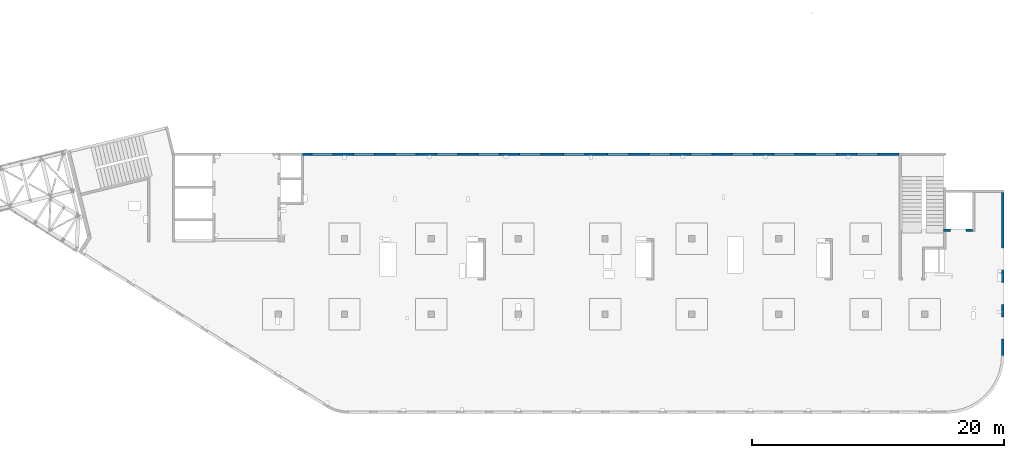
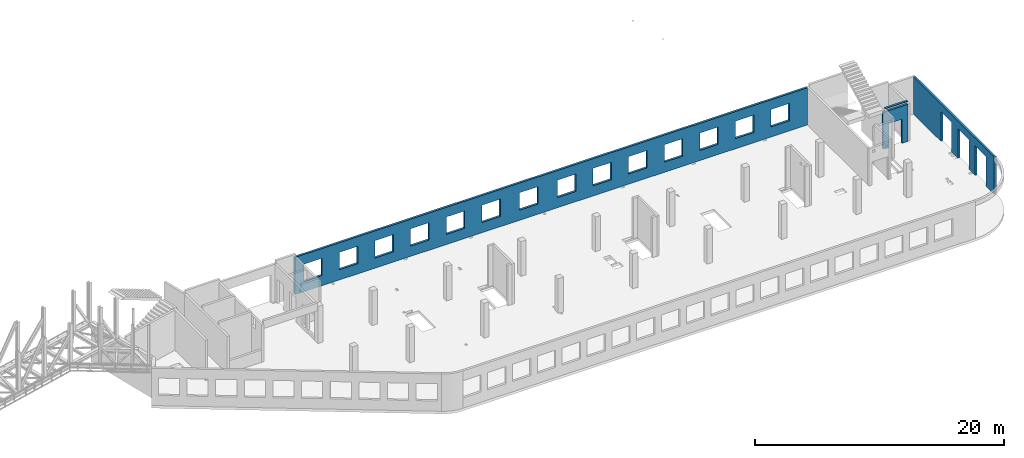
# One storey, part 92 of 92: 3 walls, 18 openings.
"""IFC4 building model written with IfcOpenShell, lengths in millimetres."""

from ifc_helpers import new_model, entity, si_unit, converted_unit, derived_unit, direction, frame, origin, place, context, subcontext, project, spatial, indexed_curve, outline, extrude, polygons, material, type_object, element, save


model = new_model("IFC4")

# Units and contexts
model_context = context("Model", 3, precision=0.01, world=origin(), true_north=direction((6.12303176911189e-17, 1.0)))
plan_context = context("Plan", 3, precision=0.01, world=origin(), true_north=direction((6.12303176911189e-17, 1.0)))
body_context = subcontext(model_context, "Body", "Model", "MODEL_VIEW")
ifc_project = project(units=[si_unit("LENGTHUNIT", "METRE", prefix="MILLI"), si_unit("AREAUNIT", "SQUARE_METRE"), si_unit("VOLUMEUNIT", "CUBIC_METRE"), converted_unit("PLANEANGLEUNIT", "DEGREE", entity("IfcRatioMeasure", 0.0174532925199433), si_unit("PLANEANGLEUNIT", "RADIAN"), dimensions=[0, 0, 0, 0, 0, 0, 0]), si_unit("MASSUNIT", "GRAM", prefix="KILO"), derived_unit("MASSDENSITYUNIT", [(si_unit("MASSUNIT", "GRAM", prefix="KILO"), 1), (si_unit("LENGTHUNIT", "METRE"), -3)]), derived_unit("MOMENTOFINERTIAUNIT", [(si_unit("LENGTHUNIT", "METRE"), 4)]), si_unit("TIMEUNIT", "SECOND"), si_unit("FREQUENCYUNIT", "HERTZ"), si_unit("THERMODYNAMICTEMPERATUREUNIT", "DEGREE_CELSIUS"), derived_unit("THERMALTRANSMITTANCEUNIT", [(si_unit("MASSUNIT", "GRAM", prefix="KILO"), 1), (si_unit("THERMODYNAMICTEMPERATUREUNIT", "KELVIN"), -1), (si_unit("TIMEUNIT", "SECOND"), -3)]), derived_unit("VOLUMETRICFLOWRATEUNIT", [(si_unit("LENGTHUNIT", "METRE"), 3), (si_unit("TIMEUNIT", "SECOND"), -1)]), derived_unit("MASSFLOWRATEUNIT", [(si_unit("MASSUNIT", "GRAM", prefix="KILO"), 1), (si_unit("TIMEUNIT", "SECOND"), -1)]), derived_unit("ROTATIONALFREQUENCYUNIT", [(si_unit("TIMEUNIT", "SECOND"), -1)]), si_unit("ELECTRICCURRENTUNIT", "AMPERE"), si_unit("ELECTRICVOLTAGEUNIT", "VOLT"), si_unit("POWERUNIT", "WATT"), si_unit("FORCEUNIT", "NEWTON", prefix="KILO"), si_unit("ILLUMINANCEUNIT", "LUX"), si_unit("LUMINOUSFLUXUNIT", "LUMEN"), si_unit("LUMINOUSINTENSITYUNIT", "CANDELA"), derived_unit("USERDEFINED", [(si_unit("MASSUNIT", "GRAM", prefix="KILO"), -1), (si_unit("LENGTHUNIT", "METRE"), -2), (si_unit("TIMEUNIT", "SECOND"), 3), (si_unit("LUMINOUSFLUXUNIT", "LUMEN"), 1)]), derived_unit("LINEARVELOCITYUNIT", [(si_unit("LENGTHUNIT", "METRE"), 1), (si_unit("TIMEUNIT", "SECOND"), -1)]), si_unit("PRESSUREUNIT", "PASCAL"), derived_unit("USERDEFINED", [(si_unit("LENGTHUNIT", "METRE"), -2), (si_unit("MASSUNIT", "GRAM", prefix="KILO"), 1), (si_unit("TIMEUNIT", "SECOND"), -2)]), derived_unit("LINEARFORCEUNIT", [(si_unit("MASSUNIT", "GRAM", prefix="KILO"), 1), (si_unit("LENGTHUNIT", "METRE"), 1), (si_unit("TIMEUNIT", "SECOND"), -2), (si_unit("LENGTHUNIT", "METRE"), -1)]), derived_unit("PLANARFORCEUNIT", [(si_unit("MASSUNIT", "GRAM", prefix="KILO"), 1), (si_unit("LENGTHUNIT", "METRE"), 1), (si_unit("TIMEUNIT", "SECOND"), -2), (si_unit("LENGTHUNIT", "METRE"), -2)])], contexts=[model_context, plan_context])

# Site, building, storey
site_placement = place(None, origin())
site = spatial("IfcSite", under=ifc_project, at=site_placement, CompositionType="ELEMENT")
building_placement = place(site_placement, origin())
building = spatial("IfcBuilding", under=site, at=building_placement, CompositionType="ELEMENT")
storey_placement = place(building_placement, frame((0.0, 0.0, 15900.0)))
storey = spatial("IfcBuildingStorey", under=building, at=storey_placement, Name="05", CompositionType="ELEMENT", Elevation=15900.0)

# Wall, openings
ifc_material = material()
wall_type = type_object("IfcWallType", Name=":ADSK_ 25_200", PredefinedType="STANDARD")
wall_1_placement = place(storey_placement, frame((73470.0, 17370.0, -150.0), z_axis=(0.0, 0.0, 1.0), x_axis=(0.0, -1.0, 0.0)))
wall_1 = element("IfcWall", 1, at=wall_1_placement, inside=storey, type_object=wall_type, material=ifc_material, Name=":ADSK_ 25_200", ObjectType=":ADSK_ 25_200", PredefinedType="NOTDEFINED", context=body_context, shape_type="Tessellation", body=[
    polygons([(12970.0, -99.9999999999918, -2.16573425859679e-12), (12970.0, -99.9999999999918, 3200.0), (12970.0, -99.9999999999918, 3650.0), (9670.00000000001, -99.9999999999876, 3650.0), (9370.00000000001, -99.999999999988, 3650.0), (0.0, -99.9999999999831, 3650.0), (0.0, -99.9999999999831, -2.16573425859679e-12), (4395.00000000004, -99.9999999999946, -2.16573425859679e-12), (4395.00000000004, -100.000000000003, 2900.0), (6145.00000000004, -100.000000000001, 2900.0), (6145.00000000004, -99.9999999999923, -2.16573425859679e-12), (6320.00000000002, -99.999999999992, 0.0), (6485.00000000003, -99.9999999999918, 0.0), (7085.00000000004, -99.999999999991, 0.0), (7145.00000000004, -99.9999999999909, -2.16573425859679e-12), (7145.00000000004, -100.000000000311, 2900.0), (8895.00000000004, -100.000000000309, 2900.0), (8895.00000000004, -99.9999999999886, -2.16573425859679e-12), (9360.00000000002, -99.999999999988, 0.0), (9560.00000000003, -99.9999999999877, 0.0), (9895.00000000005, -99.9999999999959, -2.16573425859679e-12), (9895.00000000005, -99.9999999999959, 2900.0), (11645.0, -99.9999999999936, 2900.0), (11645.0, -99.9999999999936, -2.16573425859679e-12), (12970.0, 100.000000000006, 3650.0), (12970.0, 100.000000000006, 3200.0), (12970.0, 100.000000000006, -2.16573425859679e-12), (11645.0, 100.000000000004, -2.16573425859679e-12), (11645.0, 100.000000000316, 2900.0), (9895.00000000005, 100.000000000314, 2900.0), (9895.00000000004, 100.000000000002, -2.16573425859679e-12), (8895.00000000004, 100.000000000001, -2.16573425859679e-12), (8895.00000000004, 100.000000000001, 2900.0), (7145.00000000004, 99.9999999999983, 2900.0), (7145.00000000004, 99.9999999999983, -2.16573425859679e-12), (6145.00000000004, 99.9999999999969, -2.16573425859679e-12), (6145.00000000004, 100.000000000326, 2900.0), (4395.00000000004, 100.000000000324, 2900.0), (4395.00000000004, 99.9999999999946, -2.16573425859679e-12), (0.0, 100.000000000006, -2.16573425859679e-12), (0.0, 100.000000000006, 3650.0)], [[[1, 2, 3, 4, 5, 6, 7, 8, 9, 10, 11, 12, 13, 14, 15, 16, 17, 18, 19, 20, 21, 22, 23, 24]], [[25, 26, 27, 28, 29, 30, 31, 32, 33, 34, 35, 36, 37, 38, 39, 40, 41]], [[7, 40, 39, 8]], [[3, 2, 1, 27, 26, 25]], [[6, 5, 4, 3, 25, 41]], [[7, 6, 41, 40]], [[22, 30, 29, 23]], [[30, 22, 21, 31]], [[23, 29, 28, 24]], [[33, 17, 16, 34]], [[17, 33, 32, 18]], [[34, 16, 15, 35]], [[9, 38, 37, 10]], [[38, 9, 8, 39]], [[10, 37, 36, 11]], [[35, 15, 14, 13, 12, 11, 36]], [[31, 21, 20, 19, 18, 32]], [[27, 1, 24, 28]]], closed=True),
])
placement_1 = place(wall_1_placement, frame((17370.0, -73470.0, 150.0), z_axis=(0.0, 0.0, 1.0), x_axis=(0.0, 1.0, 0.0)))
element("IfcOpeningElement", 2, at=placement_1, cuts=wall_1, Name=":ADSK_ 25_200", PredefinedType="OPENING", context=body_context, shape_type="SweptSolid", body=[
    extrude(outline(indexed_curve([(-1449.99999999999, -874.999999999999), (1450.0, -874.999999999999), (1450.0, 875.0), (-1449.99999999999, 875.0), (-1449.99999999999, -874.999999999999)], self_intersect=False)), frame((73370.0, 6600.0, 1300.0), z_axis=(1.0, 0.0, 0.0), x_axis=(0.0, 0.0, -1.0)), (0.0, 0.0, 1.0), 200.000000000968),
])
element("IfcOpeningElement", 3, at=placement_1, cuts=wall_1, Name=":ADSK_ 25_200", PredefinedType="OPENING", context=body_context, shape_type="SweptSolid", body=[
    extrude(outline(indexed_curve([(-874.999999999999, -1449.99999999999), (874.999999999999, -1449.99999999999), (874.999999999999, 1450.0), (-874.999999999999, 1450.0), (-874.999999999999, -1449.99999999999)], self_intersect=False)), frame((73370.0, 9350.0, 1300.0), z_axis=(1.0, 0.0, 0.0), x_axis=(0.0, -1.0, 0.0)), (0.0, 0.0, 1.0), 200.000000000968),
])
element("IfcOpeningElement", 4, at=placement_1, cuts=wall_1, Name=":ADSK_ 25_200", PredefinedType="OPENING", context=body_context, shape_type="SweptSolid", body=[
    extrude(outline(indexed_curve([(-1449.99999999999, -875.0), (1450.0, -875.0), (1450.0, 875.0), (-1449.99999999999, 875.0), (-1449.99999999999, -875.0)], self_intersect=False)), frame((73370.0, 12100.0, 1300.0), z_axis=(1.0, 0.0, 0.0), x_axis=(0.0, 0.0, -1.0)), (0.0, 0.0, 1.0), 200.000000000968),
])

# Wall, opening
wall_2_placement = place(storey_placement, frame((71070.0, 14370.0, -150.0), z_axis=(0.0, 0.0, 1.0), x_axis=(-1.0, 0.0, 0.0)))
wall_2 = element("IfcWall", 5, at=wall_2_placement, inside=storey, type_object=wall_type, material=ifc_material, Name=":ADSK_ 25_200", ObjectType=":ADSK_ 25_200", PredefinedType="NOTDEFINED", context=body_context, shape_type="Tessellation", body=[
    polygons([(1769.99918212887, -100.000000000003, -2.16573425859679e-12), (2099.99918212886, -100.000000000003, -2.16573425859679e-12), (2099.99918212886, -100.000000000003, 49.9999999999995), (2299.99918212887, -100.000000000003, 49.9999999999995), (2299.99918212887, -100.000000000003, 3650.0), (2099.99918212887, -100.000000000001, 3650.0), (-2.4387927500343e-12, -100.000000000001, 3650.0), (-2.4387927500343e-12, -100.000000000001, -2.16573425859679e-12), (529.999182128873, -100.000000000001, -2.16573425859679e-12), (529.999182128864, -100.000000000001, 2369.99999999805), (1769.99918212887, -99.9999999999989, 2369.99999999804), (2099.99918212886, 99.9999999999989, -2.16573425859679e-12), (1769.99918212887, 99.9999999999989, -2.16573425859679e-12), (1769.99918212887, 99.9999999999989, 2369.99999999805), (529.999182128872, 99.9999999999989, 2369.99999999805), (529.999182128872, 99.9999999999989, -2.16573425859679e-12), (-3.00376710535355e-12, 99.9999999999968, -2.16573425859679e-12), (-3.00376710535355e-12, 99.9999999999968, 3650.0), (2099.99918212887, 99.9999999999989, 3650.0), (2299.99918212887, 99.9999999999989, 3650.0), (2299.99918212887, 99.9999999999989, 49.9999999999995), (2099.99918212886, 99.9999999999989, 49.9999999999995)], [[[1, 2, 3, 4, 5, 6, 7, 8, 9, 10, 11]], [[12, 13, 14, 15, 16, 17, 18, 19, 20, 21, 22]], [[8, 17, 16, 9]], [[17, 8, 7, 18]], [[10, 15, 14, 11]], [[11, 14, 13, 1]], [[15, 10, 9, 16]], [[4, 3, 22, 21]], [[5, 20, 19, 18, 7, 6]], [[3, 2, 12, 22]], [[5, 4, 21, 20]], [[2, 1, 13, 12]]], closed=True),
    polygons([(-2.4387927500343e-12, -100.000000000001, 3950.0), (2099.99918212886, -100.000000000003, 3950.0), (2099.99918212886, 99.9999999999989, 3950.0), (-3.00376710535355e-12, 99.9999999999968, 3950.0), (2099.99918212886, -100.000000000003, 3900.0), (2099.99918212886, 99.9999999999989, 3900.0), (-2.4387927500343e-12, -100.000000000001, 3900.0), (-3.00376710535355e-12, 99.9999999999968, 3900.0)], [[[1, 2, 3, 4]], [[3, 2, 5, 6]], [[5, 7, 8, 6]], [[1, 4, 8, 7]], [[4, 3, 6, 8]], [[2, 1, 7, 5]]], closed=True),
])
opening_4_placement = place(wall_2_placement, frame((71070.0, 14370.0, 150.0), z_axis=(0.0, 0.0, 1.0), x_axis=(-1.0, 0.0, 0.0)))
element("IfcOpeningElement", 6, at=opening_4_placement, cuts=wall_2, Name=":ADSK_ 25_200", PredefinedType="OPENING", context=body_context, shape_type="SweptSolid", body=[
    extrude(outline(indexed_curve([(-619.999999999998, -1184.99999999902), (620.000000000006, -1184.99999999902), (620.000000000006, 1184.99999999902), (-619.999999999998, 1184.99999999902), (-619.999999999998, -1184.99999999902)], self_intersect=False)), frame((69920.0, 14570.0, 1035.0), z_axis=(0.0, -1.0, 0.0), x_axis=(-1.0, 0.0, 0.0)), (0.0, 0.0, 1.0), 400.000000001943),
])

# Wall, openings
wall_3_placement = place(storey_placement, frame((65230.0, 20400.0, -150.0), z_axis=(0.0, 0.0, 1.0), x_axis=(-1.0, 0.0, 0.0)))
wall_3 = element("IfcWall", 7, at=wall_3_placement, inside=storey, type_object=wall_type, material=ifc_material, Name=":ADSK_ 25_200", ObjectType=":ADSK_ 25_200", PredefinedType="NOTDEFINED", context=body_context, shape_type="Tessellation", body=[
    polygons([(8.66293703438714e-12, -99.9999999999989, -2.16573425859679e-12), (47405.0, -99.9999999999989, -2.16573425859679e-12), (47405.0, -99.9999999999989, 49.9999999999995), (47505.0, -99.9999999999989, 49.9999999999995), (47505.0, -99.9999999999989, 3650.0), (8.66293703438714e-12, -99.9999999999989, 3650.0), (28460.0, -100.000000000319, 2700.0), (30160.0, -100.000000000319, 2700.0), (30160.0, -100.000000000319, 1000.00000000001), (28460.0, -100.000000000319, 1000.00000000001), (1660.00000000009, -100.000000000319, 2700.0), (3360.00000000009, -100.000000000319, 2700.0), (3360.00000000009, -100.000000000319, 1000.00000000001), (1660.00000000009, -100.000000000319, 1000.00000000001), (4960.00000000009, -100.000000000319, 2700.0), (6660.00000000009, -100.000000000319, 2700.0), (6660.00000000009, -100.000000000319, 1000.00000000001), (4960.00000000009, -100.000000000319, 1000.00000000001), (8260.00000000008, -100.000000000319, 2700.0), (9960.00000000008, -100.000000000319, 2700.0), (9960.00000000008, -100.000000000319, 1000.00000000001), (8260.00000000008, -100.000000000319, 1000.00000000001), (11560.0000000001, -100.000000000319, 2700.0), (13260.0000000001, -100.000000000319, 2700.0), (13260.0000000001, -100.000000000319, 1000.00000000001), (11560.0000000001, -100.000000000319, 1000.00000000001), (14860.0000000001, -100.000000000319, 2700.0), (16560.0000000001, -100.000000000319, 2700.0), (16560.0000000001, -100.000000000319, 1000.00000000001), (14860.0000000001, -100.000000000319, 1000.00000000001), (18160.0000000001, -100.000000000319, 2700.0), (19860.0000000001, -100.000000000319, 2700.0), (19860.0000000001, -100.000000000319, 1000.00000000001), (18160.0000000001, -100.000000000319, 1000.00000000001), (21460.0000000001, -100.000000000319, 2700.0), (23160.0000000001, -100.000000000319, 2700.0), (23160.0000000001, -100.000000000319, 1000.00000000001), (21460.0000000001, -100.000000000319, 1000.00000000001), (24960.0000000001, -100.000000000319, 2700.0), (26660.0000000001, -100.000000000319, 2700.0), (26660.0000000001, -100.000000000319, 1000.00000000001), (24960.0000000001, -100.000000000319, 1000.00000000001), (31760.0000000001, -100.000000000319, 2700.0), (33460.0000000001, -100.000000000319, 2700.0), (33460.0000000001, -100.000000000319, 1000.00000000001), (31760.0000000001, -100.000000000319, 1000.00000000001), (35060.0000000001, -100.000000000319, 2700.0), (36760.0000000001, -100.000000000319, 2700.0), (36760.0000000001, -100.000000000319, 1000.00000000001), (35060.0000000001, -100.000000000319, 1000.00000000001), (38360.0000000001, -100.000000000319, 2700.0), (40060.0000000001, -100.000000000319, 2700.0), (40060.0000000001, -100.000000000319, 1000.00000000001), (38360.0000000001, -100.000000000319, 1000.00000000001), (41660.0, -100.000000000319, 2700.0), (43360.0, -100.000000000319, 2700.0), (43360.0, -100.000000000319, 1000.00000000001), (41660.0, -100.000000000319, 1000.00000000001), (44960.0, -100.000000000319, 2700.0), (46660.0, -100.000000000319, 2700.0), (46660.0, -100.000000000319, 1000.00000000001), (44960.0, -100.000000000319, 1000.00000000001), (30160.0, 99.9999999999989, 2700.0), (28460.0, 99.9999999999989, 2700.0), (28460.0, 99.9999999999989, 1000.00000000001), (30160.0, 99.9999999999989, 1000.00000000001), (3360.00000000009, 99.9999999999989, 2700.0), (1660.00000000009, 99.9999999999989, 2700.0), (1660.00000000009, 99.9999999999989, 1000.00000000001), (3360.00000000009, 99.9999999999989, 1000.00000000001), (6660.00000000009, 99.9999999999989, 2700.0), (4960.00000000009, 99.9999999999989, 2700.0), (4960.00000000009, 99.9999999999989, 1000.00000000001), (6660.00000000009, 99.9999999999989, 1000.00000000001), (9960.00000000008, 99.9999999999989, 2700.0), (8260.00000000008, 99.9999999999989, 2700.0), (8260.00000000008, 99.9999999999989, 1000.00000000001), (9960.00000000008, 99.9999999999989, 1000.00000000001), (13260.0000000001, 99.9999999999989, 2700.0), (11560.0000000001, 99.9999999999989, 2700.0), (11560.0000000001, 99.9999999999989, 1000.00000000001), (13260.0000000001, 99.9999999999989, 1000.00000000001), (16560.0000000001, 99.9999999999989, 2700.0), (14860.0000000001, 99.9999999999989, 2700.0), (14860.0000000001, 99.9999999999989, 1000.00000000001), (16560.0000000001, 99.9999999999989, 1000.00000000001), (19860.0000000001, 99.9999999999989, 2700.0), (18160.0000000001, 99.9999999999989, 2700.0), (18160.0000000001, 99.9999999999989, 1000.00000000001), (19860.0000000001, 99.9999999999989, 1000.00000000001), (23160.0000000001, 99.9999999999989, 2700.0), (21460.0000000001, 99.9999999999989, 2700.0), (21460.0000000001, 99.9999999999989, 1000.00000000001), (23160.0000000001, 99.9999999999989, 1000.00000000001), (26660.0000000001, 99.9999999999989, 2700.0), (24960.0000000001, 99.9999999999989, 2700.0), (24960.0000000001, 99.9999999999989, 1000.00000000001), (26660.0000000001, 99.9999999999989, 1000.00000000001), (33460.0000000001, 99.9999999999989, 2700.0), (31760.0000000001, 99.9999999999989, 2700.0), (31760.0000000001, 99.9999999999989, 1000.00000000001), (33460.0000000001, 99.9999999999989, 1000.00000000001), (36760.0000000001, 99.9999999999989, 2700.0), (35060.0000000001, 99.9999999999989, 2700.0), (35060.0000000001, 99.9999999999989, 1000.00000000001), (36760.0000000001, 99.9999999999989, 1000.00000000001), (40060.0000000001, 99.9999999999989, 2700.0), (38360.0000000001, 99.9999999999989, 2700.0), (38360.0000000001, 99.9999999999989, 1000.00000000001), (40060.0000000001, 99.9999999999989, 1000.00000000001), (43360.0, 99.9999999999989, 2700.0), (41660.0, 99.9999999999989, 2700.0), (41660.0, 99.9999999999989, 1000.00000000001), (43360.0, 99.9999999999989, 1000.00000000001), (46660.0, 99.9999999999989, 2700.0), (44960.0, 99.9999999999989, 2700.0), (44960.0, 99.9999999999989, 1000.00000000001), (46660.0, 99.9999999999989, 1000.00000000001), (8.66293703438714e-12, 99.9999999999989, -2.16573425859679e-12), (8.66293703438714e-12, 99.9999999999989, 3650.0), (47305.0, 99.9999999999989, 3650.0), (47505.0, 99.9999999999989, 3650.0), (47505.0, 99.9999999999989, 49.9999999999995), (47405.0, 99.9999999999989, 49.9999999999995), (47405.0, 99.9999999999989, -2.16573425859679e-12), (47305.0, 99.9999999999989, 0.0)], [[[1, 2, 3, 4, 5, 6], [7, 8, 9, 10], [11, 12, 13, 14], [15, 16, 17, 18], [19, 20, 21, 22], [23, 24, 25, 26], [27, 28, 29, 30], [31, 32, 33, 34], [35, 36, 37, 38], [39, 40, 41, 42], [43, 44, 45, 46], [47, 48, 49, 50], [51, 52, 53, 54], [55, 56, 57, 58], [59, 60, 61, 62]], [[119, 120, 121, 122, 123, 124, 125, 126], [63, 64, 65, 66], [67, 68, 69, 70], [71, 72, 73, 74], [75, 76, 77, 78], [79, 80, 81, 82], [83, 84, 85, 86], [87, 88, 89, 90], [91, 92, 93, 94], [95, 96, 97, 98], [99, 100, 101, 102], [103, 104, 105, 106], [107, 108, 109, 110], [111, 112, 113, 114], [115, 116, 117, 118]], [[2, 1, 119, 126, 125]], [[6, 5, 122, 121, 120]], [[8, 7, 64, 63]], [[8, 63, 66, 9]], [[9, 66, 65, 10]], [[64, 7, 10, 65]], [[12, 11, 68, 67]], [[12, 67, 70, 13]], [[13, 70, 69, 14]], [[68, 11, 14, 69]], [[16, 15, 72, 71]], [[16, 71, 74, 17]], [[17, 74, 73, 18]], [[72, 15, 18, 73]], [[20, 19, 76, 75]], [[20, 75, 78, 21]], [[21, 78, 77, 22]], [[76, 19, 22, 77]], [[24, 23, 80, 79]], [[24, 79, 82, 25]], [[25, 82, 81, 26]], [[80, 23, 26, 81]], [[28, 27, 84, 83]], [[28, 83, 86, 29]], [[29, 86, 85, 30]], [[84, 27, 30, 85]], [[32, 31, 88, 87]], [[32, 87, 90, 33]], [[33, 90, 89, 34]], [[88, 31, 34, 89]], [[36, 35, 92, 91]], [[36, 91, 94, 37]], [[37, 94, 93, 38]], [[92, 35, 38, 93]], [[40, 39, 96, 95]], [[40, 95, 98, 41]], [[41, 98, 97, 42]], [[96, 39, 42, 97]], [[44, 43, 100, 99]], [[44, 99, 102, 45]], [[45, 102, 101, 46]], [[100, 43, 46, 101]], [[48, 47, 104, 103]], [[48, 103, 106, 49]], [[49, 106, 105, 50]], [[104, 47, 50, 105]], [[52, 51, 108, 107]], [[52, 107, 110, 53]], [[53, 110, 109, 54]], [[108, 51, 54, 109]], [[56, 55, 112, 111]], [[56, 111, 114, 57]], [[57, 114, 113, 58]], [[112, 55, 58, 113]], [[60, 59, 116, 115]], [[60, 115, 118, 61]], [[61, 118, 117, 62]], [[116, 59, 62, 117]], [[3, 2, 125, 124]], [[5, 4, 123, 122]], [[1, 6, 120, 119]], [[123, 4, 3, 124]]], closed=True),
])
placement_2 = place(wall_3_placement, frame((65230.0, 20400.0, 150.0), z_axis=(0.0, 0.0, 1.0), x_axis=(-1.0, 0.0, 0.0)))
element("IfcOpeningElement", 8, at=placement_2, cuts=wall_3, Name=":ADSK_ 25_200", PredefinedType="OPENING", context=body_context, shape_type="SweptSolid", body=[
    extrude(outline(indexed_curve([(-850.000000000002, -849.999999999993), (850.0, -849.999999999993), (850.0, 849.999999999995), (-850.000000000002, 849.999999999995), (-850.000000000002, -849.999999999993)], self_intersect=False)), frame((19420.0, 20500.0, 1700.0), z_axis=(0.0, -1.0, 0.0), x_axis=(-1.0, 0.0, 0.0)), (0.0, 0.0, 1.0), 200.000000000959),
])
element("IfcOpeningElement", 9, at=placement_2, cuts=wall_3, Name=":ADSK_ 25_200", PredefinedType="OPENING", context=body_context, shape_type="SweptSolid", body=[
    extrude(outline(indexed_curve([(-850.000000000002, -849.999999999993), (849.999999999997, -849.999999999993), (849.999999999997, 849.999999999995), (-850.000000000002, 849.999999999995), (-850.000000000002, -849.999999999993)], self_intersect=False)), frame((22720.0, 20500.0, 1700.0), z_axis=(0.0, -1.0, 0.0), x_axis=(-1.0, 0.0, 0.0)), (0.0, 0.0, 1.0), 200.000000000959),
])
element("IfcOpeningElement", 10, at=placement_2, cuts=wall_3, Name=":ADSK_ 25_200", PredefinedType="OPENING", context=body_context, shape_type="SweptSolid", body=[
    extrude(outline(indexed_curve([(-850.000000000002, -849.999999999993), (849.999999999997, -849.999999999993), (849.999999999997, 849.999999999995), (-850.000000000002, 849.999999999995), (-850.000000000002, -849.999999999993)], self_intersect=False)), frame((26020.0, 20500.0, 1700.0), z_axis=(0.0, -1.0, 0.0), x_axis=(-1.0, 0.0, 0.0)), (0.0, 0.0, 1.0), 200.000000000959),
])
element("IfcOpeningElement", 11, at=placement_2, cuts=wall_3, Name=":ADSK_ 25_200", PredefinedType="OPENING", context=body_context, shape_type="SweptSolid", body=[
    extrude(outline(indexed_curve([(-850.000000000002, -849.999999999993), (849.999999999997, -849.999999999993), (849.999999999997, 849.999999999995), (-850.000000000002, 849.999999999995), (-850.000000000002, -849.999999999993)], self_intersect=False)), frame((29320.0, 20500.0, 1700.0), z_axis=(0.0, -1.0, 0.0), x_axis=(-1.0, 0.0, 0.0)), (0.0, 0.0, 1.0), 200.000000000959),
])
element("IfcOpeningElement", 12, at=placement_2, cuts=wall_3, Name=":ADSK_ 25_200", PredefinedType="OPENING", context=body_context, shape_type="SweptSolid", body=[
    extrude(outline(indexed_curve([(-849.999999999997, -849.999999999993), (850.000000000002, -849.999999999993), (850.000000000002, 849.999999999995), (-849.999999999997, 849.999999999995), (-849.999999999997, -849.999999999993)], self_intersect=False)), frame((32620.0, 20500.0, 1700.0), z_axis=(0.0, -1.0, 0.0), x_axis=(-1.0, 0.0, 0.0)), (0.0, 0.0, 1.0), 200.000000000959),
])
element("IfcOpeningElement", 13, at=placement_2, cuts=wall_3, Name=":ADSK_ 25_200", PredefinedType="OPENING", context=body_context, shape_type="SweptSolid", body=[
    extrude(outline(indexed_curve([(-849.999999999997, -849.999999999993), (850.000000000006, -849.999999999993), (850.000000000006, 849.999999999995), (-849.999999999997, 849.999999999995), (-849.999999999997, -849.999999999993)], self_intersect=False)), frame((39420.0, 20500.0, 1700.0), z_axis=(0.0, -1.0, 0.0), x_axis=(-1.0, 0.0, 0.0)), (0.0, 0.0, 1.0), 200.000000000959),
])
element("IfcOpeningElement", 14, at=placement_2, cuts=wall_3, Name=":ADSK_ 25_200", PredefinedType="OPENING", context=body_context, shape_type="SweptSolid", body=[
    extrude(outline(indexed_curve([(-850.000000000006, -849.999999999993), (849.999999999997, -849.999999999993), (849.999999999997, 849.999999999995), (-850.000000000006, 849.999999999995), (-850.000000000006, -849.999999999993)], self_intersect=False)), frame((42920.0, 20500.0, 1700.0), z_axis=(0.0, -1.0, 0.0), x_axis=(-1.0, 0.0, 0.0)), (0.0, 0.0, 1.0), 200.000000000959),
])
element("IfcOpeningElement", 15, at=placement_2, cuts=wall_3, Name=":ADSK_ 25_200", PredefinedType="OPENING", context=body_context, shape_type="SweptSolid", body=[
    extrude(outline(indexed_curve([(-849.999999999997, -849.999999999993), (850.000000000006, -849.999999999993), (850.000000000006, 849.999999999995), (-849.999999999997, 849.999999999995), (-849.999999999997, -849.999999999993)], self_intersect=False)), frame((46220.0, 20500.0, 1700.0), z_axis=(0.0, -1.0, 0.0), x_axis=(-1.0, 0.0, 0.0)), (0.0, 0.0, 1.0), 200.000000000959),
])
element("IfcOpeningElement", 16, at=placement_2, cuts=wall_3, Name=":ADSK_ 25_200", PredefinedType="OPENING", context=body_context, shape_type="SweptSolid", body=[
    extrude(outline(indexed_curve([(-849.999999999997, -849.999999999993), (850.000000000006, -849.999999999993), (850.000000000006, 849.999999999995), (-849.999999999997, 849.999999999995), (-849.999999999997, -849.999999999993)], self_intersect=False)), frame((49520.0, 20500.0, 1700.0), z_axis=(0.0, -1.0, 0.0), x_axis=(-1.0, 0.0, 0.0)), (0.0, 0.0, 1.0), 200.000000000959),
])
element("IfcOpeningElement", 17, at=placement_2, cuts=wall_3, Name=":ADSK_ 25_200", PredefinedType="OPENING", context=body_context, shape_type="SweptSolid", body=[
    extrude(outline(indexed_curve([(-849.999999999997, -849.999999999993), (850.000000000006, -849.999999999993), (850.000000000006, 849.999999999995), (-849.999999999997, 849.999999999995), (-849.999999999997, -849.999999999993)], self_intersect=False)), frame((52820.0, 20500.0, 1700.0), z_axis=(0.0, -1.0, 0.0), x_axis=(-1.0, 0.0, 0.0)), (0.0, 0.0, 1.0), 200.000000000959),
])
element("IfcOpeningElement", 18, at=placement_2, cuts=wall_3, Name=":ADSK_ 25_200", PredefinedType="OPENING", context=body_context, shape_type="SweptSolid", body=[
    extrude(outline(indexed_curve([(-849.999999999997, -849.999999999993), (850.000000000006, -849.999999999993), (850.000000000006, 849.999999999995), (-849.999999999997, 849.999999999995), (-849.999999999997, -849.999999999993)], self_intersect=False)), frame((56120.0, 20500.0, 1700.0), z_axis=(0.0, -1.0, 0.0), x_axis=(-1.0, 0.0, 0.0)), (0.0, 0.0, 1.0), 200.000000000959),
])
element("IfcOpeningElement", 19, at=placement_2, cuts=wall_3, Name=":ADSK_ 25_200", PredefinedType="OPENING", context=body_context, shape_type="SweptSolid", body=[
    extrude(outline(indexed_curve([(-849.999999999997, -849.999999999993), (850.000000000006, -849.999999999993), (850.000000000006, 849.999999999995), (-849.999999999997, 849.999999999995), (-849.999999999997, -849.999999999993)], self_intersect=False)), frame((59420.0, 20500.0, 1700.0), z_axis=(0.0, -1.0, 0.0), x_axis=(-1.0, 0.0, 0.0)), (0.0, 0.0, 1.0), 200.000000000959),
])
element("IfcOpeningElement", 20, at=placement_2, cuts=wall_3, Name=":ADSK_ 25_200", PredefinedType="OPENING", context=body_context, shape_type="SweptSolid", body=[
    extrude(outline(indexed_curve([(-849.999999999997, -849.999999999993), (850.000000000006, -849.999999999993), (850.000000000006, 849.999999999995), (-849.999999999997, 849.999999999995), (-849.999999999997, -849.999999999993)], self_intersect=False)), frame((62720.0, 20500.0, 1700.0), z_axis=(0.0, -1.0, 0.0), x_axis=(-1.0, 0.0, 0.0)), (0.0, 0.0, 1.0), 200.000000000959),
])
element("IfcOpeningElement", 21, at=placement_2, cuts=wall_3, Name=":ADSK_ 25_200", PredefinedType="OPENING", context=body_context, shape_type="SweptSolid", body=[
    extrude(outline(indexed_curve([(-849.999999999997, -849.999999999993), (850.000000000002, -849.999999999993), (850.000000000002, 849.999999999995), (-849.999999999997, 849.999999999995), (-849.999999999997, -849.999999999993)], self_intersect=False)), frame((35920.0, 20500.0, 1700.0), z_axis=(0.0, -1.0, 0.0), x_axis=(-1.0, 0.0, 0.0)), (0.0, 0.0, 1.0), 200.000000000959),
])

save(model, "model.ifc")
